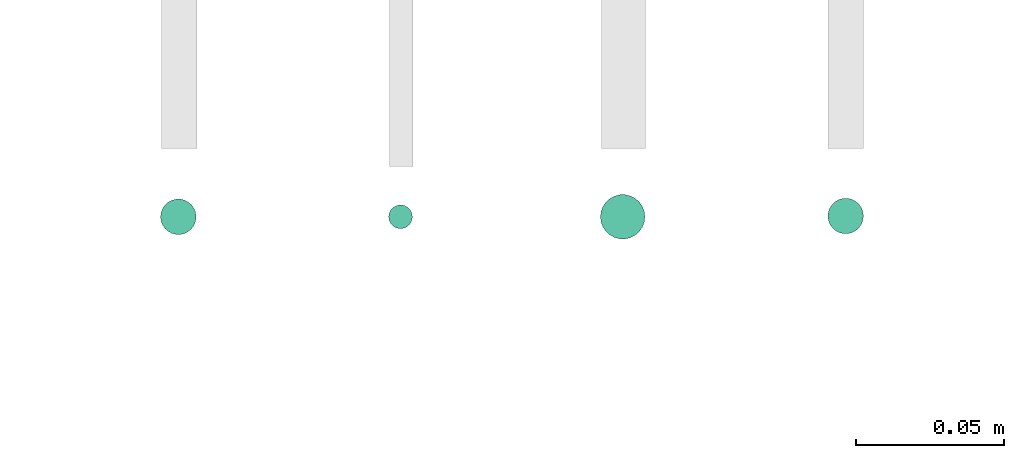
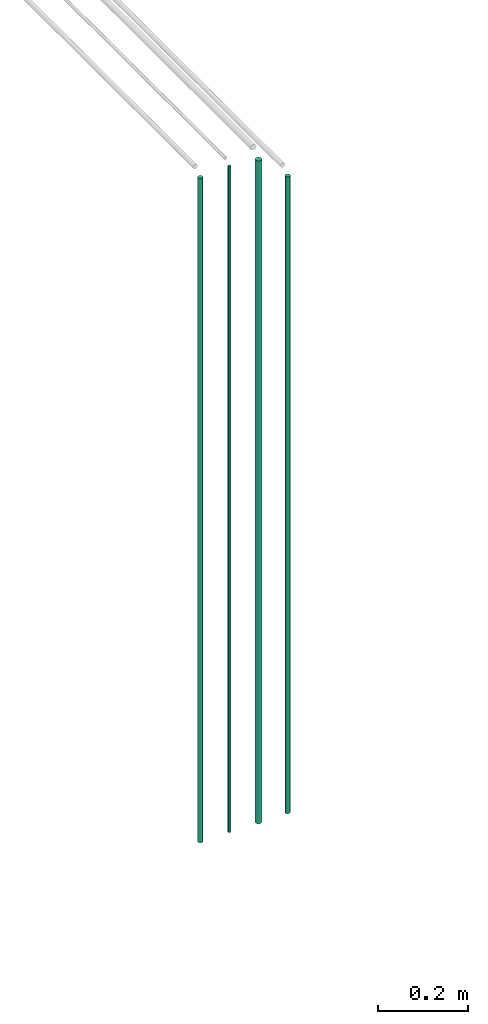
# One storey, part 21 of 65: 4 flow segments.
"""IFC2X3 building model written with IfcOpenShell, lengths in millimetres."""

from ifc_helpers import new_model, entity, si_unit, converted_unit, derived_unit, direction, frame, frame_2d, origin, origin_2d_with_axis, place, context, subcontext, project, spatial, circle, extrude, type_object, element, save


model = new_model("IFC2X3")

# Units and contexts
model_context = context("Model", 3, precision=0.01, world=origin(), true_north=direction((6.12303176911189e-17, 1.0)))
body_context = subcontext(model_context, "Body", "Model", "MODEL_VIEW")
ifc_project = project(units=[si_unit("LENGTHUNIT", "METRE", prefix="MILLI"), si_unit("AREAUNIT", "SQUARE_METRE"), si_unit("VOLUMEUNIT", "CUBIC_METRE"), converted_unit("PLANEANGLEUNIT", "DEGREE", entity("IfcRatioMeasure", 0.0174532925199433), si_unit("PLANEANGLEUNIT", "RADIAN"), dimensions=[0, 0, 0, 0, 0, 0, 0]), si_unit("MASSUNIT", "GRAM", prefix="KILO"), derived_unit("MASSDENSITYUNIT", [(si_unit("MASSUNIT", "GRAM", prefix="KILO"), 1), (si_unit("LENGTHUNIT", "METRE"), -3)]), derived_unit("MOMENTOFINERTIAUNIT", [(si_unit("LENGTHUNIT", "METRE"), 4)]), si_unit("TIMEUNIT", "SECOND"), si_unit("FREQUENCYUNIT", "HERTZ"), si_unit("THERMODYNAMICTEMPERATUREUNIT", "DEGREE_CELSIUS"), derived_unit("THERMALTRANSMITTANCEUNIT", [(si_unit("MASSUNIT", "GRAM", prefix="KILO"), 1), (si_unit("THERMODYNAMICTEMPERATUREUNIT", "KELVIN"), -1), (si_unit("TIMEUNIT", "SECOND"), -3)]), derived_unit("VOLUMETRICFLOWRATEUNIT", [(si_unit("LENGTHUNIT", "METRE"), 3), (si_unit("TIMEUNIT", "SECOND"), -1)]), derived_unit("MASSFLOWRATEUNIT", [(si_unit("MASSUNIT", "GRAM", prefix="KILO"), 1), (si_unit("TIMEUNIT", "SECOND"), -1)]), derived_unit("ROTATIONALFREQUENCYUNIT", [(si_unit("TIMEUNIT", "SECOND"), -1)]), si_unit("ELECTRICCURRENTUNIT", "AMPERE"), si_unit("ELECTRICVOLTAGEUNIT", "VOLT"), si_unit("POWERUNIT", "WATT"), si_unit("FORCEUNIT", "NEWTON", prefix="KILO"), si_unit("ILLUMINANCEUNIT", "LUX"), si_unit("LUMINOUSFLUXUNIT", "LUMEN"), si_unit("LUMINOUSINTENSITYUNIT", "CANDELA"), derived_unit("USERDEFINED", [(si_unit("MASSUNIT", "GRAM", prefix="KILO"), -1), (si_unit("LENGTHUNIT", "METRE"), -2), (si_unit("TIMEUNIT", "SECOND"), 3), (si_unit("LUMINOUSFLUXUNIT", "LUMEN"), 1)]), derived_unit("LINEARVELOCITYUNIT", [(si_unit("LENGTHUNIT", "METRE"), 1), (si_unit("TIMEUNIT", "SECOND"), -1)]), si_unit("PRESSUREUNIT", "PASCAL"), derived_unit("USERDEFINED", [(si_unit("LENGTHUNIT", "METRE"), -2), (si_unit("MASSUNIT", "GRAM", prefix="KILO"), 1), (si_unit("TIMEUNIT", "SECOND"), -2)]), derived_unit("LINEARFORCEUNIT", [(si_unit("MASSUNIT", "GRAM", prefix="KILO"), 1), (si_unit("LENGTHUNIT", "METRE"), 1), (si_unit("TIMEUNIT", "SECOND"), -2), (si_unit("LENGTHUNIT", "METRE"), -1)]), derived_unit("PLANARFORCEUNIT", [(si_unit("MASSUNIT", "GRAM", prefix="KILO"), 1), (si_unit("LENGTHUNIT", "METRE"), 1), (si_unit("TIMEUNIT", "SECOND"), -2), (si_unit("LENGTHUNIT", "METRE"), -2)])], contexts=[model_context])

# Site, building, storey
site_placement = place(None, frame((0.0, -0.00077364408347762, 0.0)))
site = spatial("IfcSite", under=ifc_project, at=site_placement, CompositionType="ELEMENT")
building_placement = place(site_placement, origin())
building = spatial("IfcBuilding", under=site, at=building_placement, CompositionType="ELEMENT")
storey_placement = place(building_placement, frame((0.0, 0.0, 19800.0)))
storey = spatial("IfcBuildingStorey", under=building, at=storey_placement, CompositionType="ELEMENT", Elevation=19800.0)

# Flow segments
pipe_segment_type = type_object("IfcPipeSegmentType", PredefinedType="NOTDEFINED")
flow_segment_1_placement = place(storey_placement, frame((67371.5323269755, 763.960170480074, 1400.0)))
element("IfcFlowSegment", 1, at=flow_segment_1_placement, inside=storey, type_object=pipe_segment_type, context=body_context, shape_type="SweptSolid", body=[
    extrude(circle(Radius=6.0, at=origin_2d_with_axis()), frame((7.59527223591454, 7.59527223591603, 0.0), z_axis=(0.0, 0.0, 1.0), x_axis=(-1.0, 0.0, 0.0)), (0.0, 0.0, 1.0), 1811.0),
])
flow_segment_2_placement = place(storey_placement, frame((67448.5323269755, 765.960170480074, 1400.0)))
element("IfcFlowSegment", 2, at=flow_segment_2_placement, inside=storey, type_object=pipe_segment_type, context=body_context, shape_type="SweptSolid", body=[
    extrude(circle(Radius=4.0, at=frame_2d((0.0, 1.35358391162299e-13), x_axis=(1.0, 0.0))), frame((5.59527223591499, 5.59527223591621, 0.0), z_axis=(0.0, 0.0, 1.0), x_axis=(-1.0, 0.0, 0.0)), (0.0, 0.0, 1.0), 1815.0),
])
flow_segment_3_placement = place(storey_placement, frame((67520.0323269755, 762.460170480074, 1400.0)))
element("IfcFlowSegment", 3, at=flow_segment_3_placement, inside=storey, type_object=pipe_segment_type, context=body_context, shape_type="SweptSolid", body=[
    extrude(circle(Radius=7.5, at=origin_2d_with_axis()), frame((9.09527223591419, 9.09527223591609, 0.0), z_axis=(0.0, 0.0, 1.0), x_axis=(-1.0, 0.0, 0.0)), (0.0, 0.0, 1.0), 1807.0),
])
flow_segment_4_placement = place(storey_placement, frame((67596.7991206651, 764.226964169611, 1400.0)))
element("IfcFlowSegment", 4, at=flow_segment_4_placement, inside=storey, type_object=pipe_segment_type, context=body_context, shape_type="SweptSolid", body=[
    extrude(circle(Radius=6.0, at=origin_2d_with_axis()), frame((7.59527223591454, 7.59527223591603, 0.0), z_axis=(0.0, 0.0, 1.0), x_axis=(-1.0, 0.0, 0.0)), (0.0, 0.0, 1.0), 1736.0),
])

save(model, "model.ifc")
